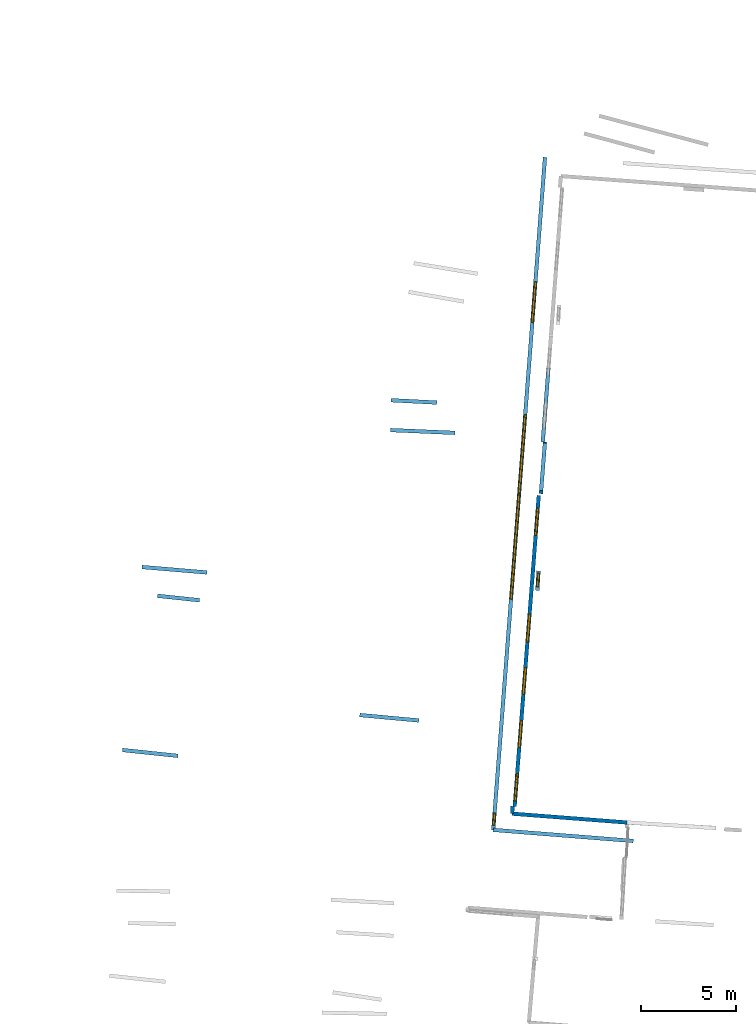
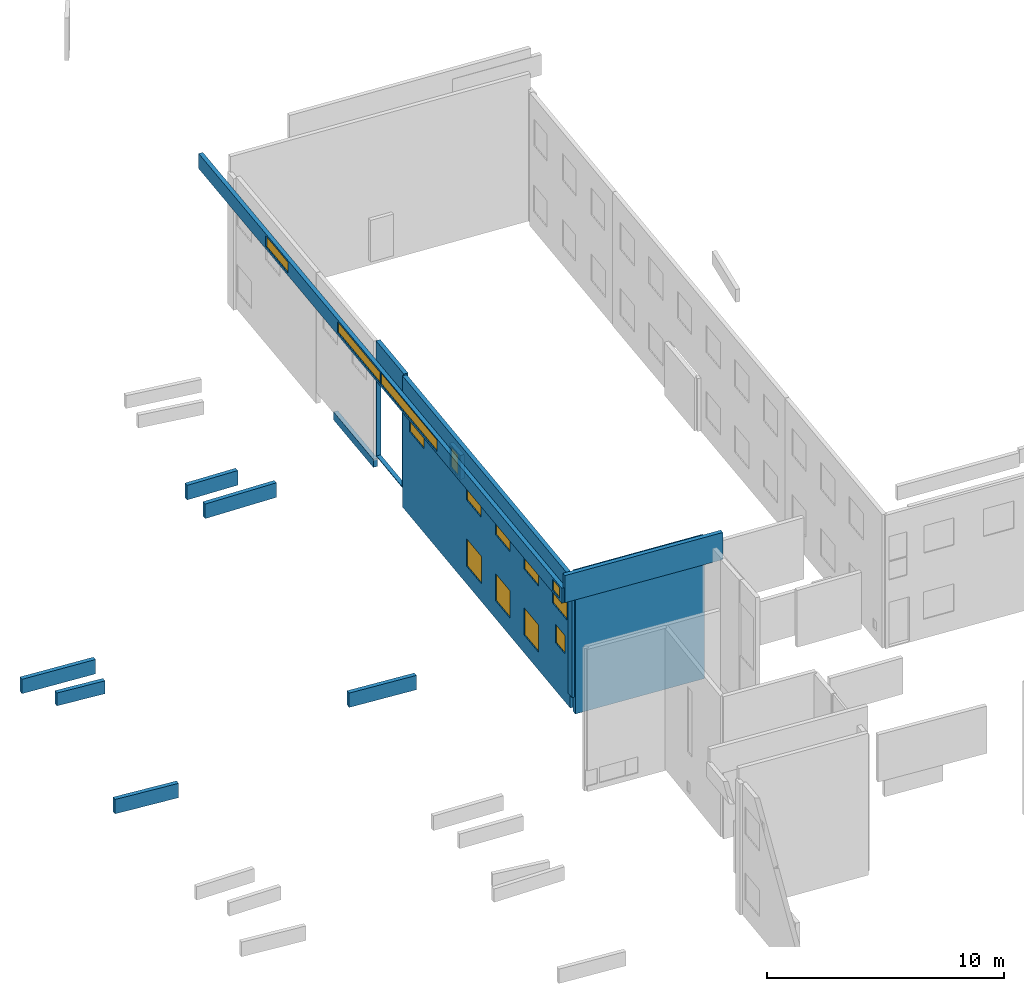
# One storey, part 9 of 27: 14 walls, 14 windows, 15 openings.
"""IFC2X3 building model written with IfcOpenShell, lengths in metres."""

from ifc_helpers import new_model, entity, si_unit, converted_unit, derived_unit, direction, frame, frame_2d, origin, origin_2d_with_axis, place, context, subcontext, project, spatial, polyline, rectangle, outline, extrude, source, transform, mapped, material, layer, layer_set, layer_usage, type_object, type_shapes, element, fill, save


model = new_model("IFC2X3")

# Units and contexts
model_context = context("Model", 3, precision=1e-05, world=origin(), true_north=direction((0.0, 1.0)))
body_context = subcontext(model_context, "Body", "Model", "MODEL_VIEW")
ifc_project = project(units=[si_unit("LENGTHUNIT", "METRE"), si_unit("AREAUNIT", "SQUARE_METRE"), si_unit("VOLUMEUNIT", "CUBIC_METRE"), converted_unit("PLANEANGLEUNIT", "DEGREE", entity("IfcRatioMeasure", 0.0174532925199433), si_unit("PLANEANGLEUNIT", "RADIAN"), dimensions=[0, 0, 0, 0, 0, 0, 0]), si_unit("MASSUNIT", "GRAM", prefix="KILO"), derived_unit("MASSDENSITYUNIT", [(si_unit("MASSUNIT", "GRAM", prefix="KILO"), 1), (si_unit("LENGTHUNIT", "METRE"), -3)]), derived_unit("MOMENTOFINERTIAUNIT", [(si_unit("LENGTHUNIT", "METRE"), 4)]), si_unit("TIMEUNIT", "SECOND"), si_unit("FREQUENCYUNIT", "HERTZ"), si_unit("THERMODYNAMICTEMPERATUREUNIT", "DEGREE_CELSIUS"), derived_unit("THERMALTRANSMITTANCEUNIT", [(si_unit("MASSUNIT", "GRAM", prefix="KILO"), 1), (si_unit("THERMODYNAMICTEMPERATUREUNIT", "KELVIN"), -1), (si_unit("TIMEUNIT", "SECOND"), -3)]), derived_unit("VOLUMETRICFLOWRATEUNIT", [(si_unit("LENGTHUNIT", "METRE"), 3), (si_unit("TIMEUNIT", "SECOND"), -1)]), si_unit("ELECTRICCURRENTUNIT", "AMPERE"), si_unit("ELECTRICVOLTAGEUNIT", "VOLT"), si_unit("POWERUNIT", "WATT"), si_unit("FORCEUNIT", "NEWTON", prefix="KILO"), si_unit("ILLUMINANCEUNIT", "LUX"), si_unit("LUMINOUSFLUXUNIT", "LUMEN"), si_unit("LUMINOUSINTENSITYUNIT", "CANDELA"), derived_unit("USERDEFINED", [(si_unit("MASSUNIT", "GRAM", prefix="KILO"), -1), (si_unit("LENGTHUNIT", "METRE"), -2), (si_unit("TIMEUNIT", "SECOND"), 3), (si_unit("LUMINOUSFLUXUNIT", "LUMEN"), 1)]), derived_unit("LINEARVELOCITYUNIT", [(si_unit("LENGTHUNIT", "METRE"), 1), (si_unit("TIMEUNIT", "SECOND"), -1)]), si_unit("PRESSUREUNIT", "PASCAL"), derived_unit("USERDEFINED", [(si_unit("LENGTHUNIT", "METRE"), -2), (si_unit("MASSUNIT", "GRAM", prefix="KILO"), 1), (si_unit("TIMEUNIT", "SECOND"), -2)]), derived_unit("LINEARFORCEUNIT", [(si_unit("MASSUNIT", "GRAM", prefix="KILO"), 1), (si_unit("LENGTHUNIT", "METRE"), 1), (si_unit("TIMEUNIT", "SECOND"), -2), (si_unit("LENGTHUNIT", "METRE"), -1)]), derived_unit("PLANARFORCEUNIT", [(si_unit("MASSUNIT", "GRAM", prefix="KILO"), 1), (si_unit("LENGTHUNIT", "METRE"), 1), (si_unit("TIMEUNIT", "SECOND"), -2), (si_unit("LENGTHUNIT", "METRE"), -2)])], contexts=[model_context])

# Site, building, storey
placement_1 = place(None, origin())
site = spatial("IfcSite", under=ifc_project, at=placement_1, CompositionType="ELEMENT")
building = spatial("IfcBuilding", under=site, at=placement_1, CompositionType="ELEMENT")
storey_placement = place(placement_1, frame((0.0, 0.0, -61.043098449707)))
storey = spatial("IfcBuildingStorey", under=building, at=storey_placement, Name="level_-61.043098", CompositionType="ELEMENT", Elevation=-61.043098449707)

# Walls
ifc_material_1 = material(Name="Default wall")
ifc_layer = layer(ifc_material_1, 0.2)
ifc_layer_set = layer_set([ifc_layer], Name="wall_thickness_0.2000")
ifc_layer_usage = layer_usage(ifc_layer_set, "AXIS2", "POSITIVE", -0.1)
wall_type = type_object("IfcWallType", Name="wall_thickness_0.2000", PredefinedType="STANDARD", material=ifc_layer_set)
placement_2 = place(placement_1, frame((0.0, 0.0, -60.9578857421875)))
wall_1_placement = place(placement_2, frame((-104.83050371707, 5.95232579703407, 0.0), z_axis=(0.0, 0.0, 1.0), x_axis=(0.994467965753538, -0.105040302217857, 0.0)))
element("IfcWallStandardCase", 1, at=wall_1_placement, inside=storey, type_object=wall_type, material=ifc_layer_usage, Name="Wall:453", ObjectType="Wall", context=body_context, shape_type="SweptSolid", body=[
    extrude(outline(polyline([(2.9369933976669, -0.1), (2.9369933976669, 0.1), (0.0, 0.1), (0.0, -0.1), (2.9369933976669, -0.1)])), origin(), (0.0, 0.0, 1.0), 0.739894866943359),
])
placement_3 = place(placement_1, frame((0.0, 0.0, -60.9578857421875)))
wall_2_placement = place(placement_3, frame((-103.806959196289, 15.56809564699, 0.0), z_axis=(0.0, 0.0, 1.0), x_axis=(0.996499432256077, -0.0835995305807164, 0.0)))
element("IfcWallStandardCase", 2, at=wall_2_placement, inside=storey, type_object=wall_type, material=ifc_layer_usage, Name="Wall:468", ObjectType="Wall", context=body_context, shape_type="SweptSolid", body=[
    extrude(outline(polyline([(3.42499908487416, -0.1), (3.42499908487416, 0.1), (0.0, 0.1), (0.0, -0.1), (3.42499908487416, -0.1)])), origin(), (0.0, 0.0, 1.0), 0.739894866943359),
])
placement_4 = place(placement_1, frame((0.0, 0.0, -60.8847198486328)))
wall_3_placement = place(placement_4, frame((-90.7094349901789, 24.3314856297393, 0.0), z_axis=(0.0, 0.0, 1.0), x_axis=(0.998708012767154, -0.0508163874619398, 0.0)))
element("IfcWallStandardCase", 3, at=wall_3_placement, inside=storey, type_object=wall_type, material=ifc_layer_usage, Name="Wall:595", ObjectType="Wall", context=body_context, shape_type="SweptSolid", body=[
    extrude(outline(polyline([(2.40143330965317, -0.1), (2.40143330965317, 0.1), (0.0, 0.1), (0.0, -0.1), (2.40143330965317, -0.1)])), origin(), (0.0, 0.0, 1.0), 0.751243591308594),
])

# Wall, openings, windows
placement_5 = place(placement_1, frame((0.0, 0.0, -60.9578857421875)))
wall_4_placement = place(placement_5, frame((-82.9530184514363, 19.3352135114914, 0.0), z_axis=(0.0, 0.0, 1.0), x_axis=(-0.0773158542007588, -0.997006649270308, 0.0)))
wall_4 = element("IfcWallStandardCase", 4, at=wall_4_placement, inside=storey, type_object=wall_type, material=ifc_layer_usage, Name="Wall:641", ObjectType="Wall", context=body_context, shape_type="SweptSolid", body=[
    extrude(outline(polyline([(16.3949994072059, -0.1), (16.3949994072059, 0.1), (0.0, 0.1), (0.0, -0.1), (16.3949994072059, -0.1)])), origin(), (0.0, 0.0, 1.0), 6.74871063232422),
])
opening_1_placement = place(wall_4_placement, frame((0.675013523373831, -0.1, 4.32080459594727)))
opening_1 = element("IfcOpeningElement", 5, at=opening_1_placement, cuts=wall_4, Name="Opening : 1420 x 1405 : 55", ObjectType="Opening", context=body_context, shape_type="SweptSolid", body=[
    extrude(rectangle(XDim=1.42, YDim=1.405, at=frame_2d((0.7025, 0.71), x_axis=(0.0, 1.0))), frame((0.0, 0.0, 0.0), z_axis=(0.0, 1.0, 0.0), x_axis=(0.0, 0.0, 1.0)), (0.0, 0.0, 1.0), 0.2),
])
opening_2_placement = place(wall_4_placement, frame((6.27501483527464, -0.1, 4.32080459594727)))
opening_2 = element("IfcOpeningElement", 6, at=opening_2_placement, cuts=wall_4, Name="Opening : 1420 x 1400 : 56", ObjectType="Opening", context=body_context, shape_type="SweptSolid", body=[
    extrude(rectangle(XDim=1.42, YDim=1.4, at=frame_2d((0.7, 0.71), x_axis=(0.0, 1.0))), frame((0.0, 0.0, 0.0), z_axis=(0.0, 1.0, 0.0), x_axis=(0.0, 0.0, 1.0)), (0.0, 0.0, 1.0), 0.2),
])
opening_3_placement = place(wall_4_placement, frame((6.26501384893207, -0.1, 0.910804748535156)))
opening_3 = element("IfcOpeningElement", 7, at=opening_3_placement, cuts=wall_4, Name="Opening : 1465 x 1415 : 57", ObjectType="Opening", context=body_context, shape_type="SweptSolid", body=[
    extrude(rectangle(XDim=1.465, YDim=1.415, at=frame_2d((0.7075, 0.7325), x_axis=(0.0, 1.0))), frame((0.0, 0.0, 0.0), z_axis=(0.0, 1.0, 0.0), x_axis=(0.0, 0.0, 1.0)), (0.0, 0.0, 1.0), 0.2),
])
opening_4_placement = place(wall_4_placement, frame((9.08499972376067, -0.1, 4.3271369934082)))
opening_4 = element("IfcOpeningElement", 8, at=opening_4_placement, cuts=wall_4, Name="Opening : 1410 x 1395 : 58", ObjectType="Opening", context=body_context, shape_type="SweptSolid", body=[
    extrude(rectangle(XDim=1.41, YDim=1.395, at=frame_2d((0.6975, 0.705), x_axis=(0.0, 1.0))), frame((0.0, 0.0, 0.0), z_axis=(0.0, 1.0, 0.0), x_axis=(0.0, 0.0, 1.0)), (0.0, 0.0, 1.0), 0.2),
])
opening_5_placement = place(wall_4_placement, frame((11.8699999654802, -0.1, 4.317138671875)))
opening_5 = element("IfcOpeningElement", 9, at=opening_5_placement, cuts=wall_4, Name="Opening : 1420 x 1400 : 59", ObjectType="Opening", context=body_context, shape_type="SweptSolid", body=[
    extrude(rectangle(XDim=1.42, YDim=1.4, at=frame_2d((0.7, 0.71), x_axis=(0.0, 1.0))), frame((0.0, 0.0, 0.0), z_axis=(0.0, 1.0, 0.0), x_axis=(0.0, 0.0, 1.0)), (0.0, 0.0, 1.0), 0.2),
])
opening_6_placement = place(wall_4_placement, frame((14.6699991952011, -0.1, 4.3271369934082)))
opening_6 = element("IfcOpeningElement", 10, at=opening_6_placement, cuts=wall_4, Name="Opening : 1420 x 1390 : 60", ObjectType="Opening", context=body_context, shape_type="SweptSolid", body=[
    extrude(rectangle(XDim=1.42, YDim=1.39, at=frame_2d((0.695, 0.71), x_axis=(0.0, 1.0))), frame((0.0, 0.0, 0.0), z_axis=(0.0, 1.0, 0.0), x_axis=(0.0, 0.0, 1.0)), (0.0, 0.0, 1.0), 0.2),
])
opening_7_placement = place(wall_4_placement, frame((14.9699989224421, -0.1, 2.46213912963867)))
opening_7 = element("IfcOpeningElement", 11, at=opening_7_placement, cuts=wall_4, Name="Opening : 895 x 945 : 61", ObjectType="Opening", context=body_context, shape_type="SweptSolid", body=[
    extrude(rectangle(XDim=0.895, YDim=0.945, at=frame_2d((0.4725, 0.4475), x_axis=(0.0, 1.0))), frame((0.0, 0.0, 0.0), z_axis=(0.0, 1.0, 0.0), x_axis=(0.0, 0.0, 1.0)), (0.0, 0.0, 1.0), 0.2),
])
opening_8_placement = place(wall_4_placement, frame((9.0799997059992, -0.1, 0.917137145996094)))
opening_8 = element("IfcOpeningElement", 12, at=opening_8_placement, cuts=wall_4, Name="Opening : 1410 x 1400 : 62", ObjectType="Opening", context=body_context, shape_type="SweptSolid", body=[
    extrude(rectangle(XDim=1.41, YDim=1.4, at=frame_2d((0.7, 0.705), x_axis=(0.0, 1.0))), frame((0.0, 0.0, 0.0), z_axis=(0.0, 1.0, 0.0), x_axis=(0.0, 0.0, 1.0)), (0.0, 0.0, 1.0), 0.2),
])
opening_9_placement = place(wall_4_placement, frame((11.8749999832417, -0.1, 0.917137145996094)))
opening_9 = element("IfcOpeningElement", 13, at=opening_9_placement, cuts=wall_4, Name="Opening : 1415 x 1400 : 63", ObjectType="Opening", context=body_context, shape_type="SweptSolid", body=[
    extrude(rectangle(XDim=1.415, YDim=1.4, at=frame_2d((0.7, 0.7075), x_axis=(0.0, 1.0))), frame((0.0, 0.0, 0.0), z_axis=(0.0, 1.0, 0.0), x_axis=(0.0, 0.0, 1.0)), (0.0, 0.0, 1.0), 0.2),
])
ifc_material_2 = material(Name="Window Default")
window_style_1 = type_object("IfcWindowStyle", Name="Window : 1420 x 1390mm", ConstructionType="NOTDEFINED", OperationType="NOTDEFINED", ParameterTakesPrecedence=False, Sizeable=False, material=ifc_material_2)
shared_shape_1 = source(origin(), body_context, "Body", "SweptSolid", [
    extrude(rectangle(XDim=0.1, YDim=1.42, at=origin_2d_with_axis()), frame((0.71, 0.1, 0.0), z_axis=(0.0, 0.0, 1.0), x_axis=(0.0, 1.0, 0.0)), (0.0, 0.0, 1.0), 1.39),
])
type_shapes(window_style_1, [shared_shape_1])
window_1_placement = place(opening_6_placement, origin())
window_1 = element("IfcWindow", 14, at=window_1_placement, inside=storey, type_object=window_style_1, Name="Window : 1420 x 1390mm : 52", ObjectType="Window : 1420 x 1390mm", OverallHeight=1.39, OverallWidth=1.42, context=body_context, shape_type="MappedRepresentation", body=[
    mapped(shared_shape_1, transform((0.0, 0.0, 0.0), scale=1.0)),
])
fill(opening_6, window_1)
window_style_2 = type_object("IfcWindowStyle", Name="Window : 1410 x 1395mm", ConstructionType="NOTDEFINED", OperationType="NOTDEFINED", ParameterTakesPrecedence=False, Sizeable=False, material=ifc_material_2)
shared_shape_2 = source(origin(), body_context, "Body", "SweptSolid", [
    extrude(rectangle(XDim=0.1, YDim=1.41, at=origin_2d_with_axis()), frame((0.705, 0.1, 0.0), z_axis=(0.0, 0.0, 1.0), x_axis=(0.0, 1.0, 0.0)), (0.0, 0.0, 1.0), 1.395),
])
type_shapes(window_style_2, [shared_shape_2])
window_2_placement = place(opening_4_placement, origin())
window_2 = element("IfcWindow", 15, at=window_2_placement, inside=storey, type_object=window_style_2, Name="Window : 1410 x 1395mm : 50", ObjectType="Window : 1410 x 1395mm", OverallHeight=1.395, OverallWidth=1.41, context=body_context, shape_type="MappedRepresentation", body=[
    mapped(shared_shape_2, transform((0.0, 0.0, 0.0), scale=1.0)),
])
fill(opening_4, window_2)
window_style_3 = type_object("IfcWindowStyle", Name="Window : 1420 x 1400mm", ConstructionType="NOTDEFINED", OperationType="NOTDEFINED", ParameterTakesPrecedence=False, Sizeable=False, material=ifc_material_2)
shared_shape_3 = source(origin(), body_context, "Body", "SweptSolid", [
    extrude(rectangle(XDim=0.1, YDim=1.42, at=origin_2d_with_axis()), frame((0.71, 0.1, 0.0), z_axis=(0.0, 0.0, 1.0), x_axis=(0.0, 1.0, 0.0)), (0.0, 0.0, 1.0), 1.4),
])
type_shapes(window_style_3, [shared_shape_3])
window_3_placement = place(opening_2_placement, origin())
window_3 = element("IfcWindow", 16, at=window_3_placement, inside=storey, type_object=window_style_3, Name="Window : 1420 x 1400mm : 48", ObjectType="Window : 1420 x 1400mm", OverallHeight=1.4, OverallWidth=1.42, context=body_context, shape_type="MappedRepresentation", body=[
    mapped(shared_shape_3, transform((0.0, 0.0, 0.0), scale=1.0)),
])
fill(opening_2, window_3)
window_4_placement = place(opening_5_placement, origin())
window_4 = element("IfcWindow", 17, at=window_4_placement, inside=storey, type_object=window_style_3, Name="Window : 1420 x 1400mm : 51", ObjectType="Window : 1420 x 1400mm", OverallHeight=1.4, OverallWidth=1.42, context=body_context, shape_type="MappedRepresentation", body=[
    mapped(shared_shape_3, transform((0.0, 0.0, 0.0), scale=1.0)),
])
fill(opening_5, window_4)
window_style_4 = type_object("IfcWindowStyle", Name="Window : 1420 x 1405mm", ConstructionType="NOTDEFINED", OperationType="NOTDEFINED", ParameterTakesPrecedence=False, Sizeable=False, material=ifc_material_2)
shared_shape_4 = source(origin(), body_context, "Body", "SweptSolid", [
    extrude(rectangle(XDim=0.1, YDim=1.42, at=origin_2d_with_axis()), frame((0.71, 0.1, 0.0), z_axis=(0.0, 0.0, 1.0), x_axis=(0.0, 1.0, 0.0)), (0.0, 0.0, 1.0), 1.405),
])
type_shapes(window_style_4, [shared_shape_4])
window_5_placement = place(opening_1_placement, origin())
window_5 = element("IfcWindow", 18, at=window_5_placement, inside=storey, type_object=window_style_4, Name="Window : 1420 x 1405mm : 47", ObjectType="Window : 1420 x 1405mm", OverallHeight=1.405, OverallWidth=1.42, context=body_context, shape_type="MappedRepresentation", body=[
    mapped(shared_shape_4, transform((0.0, 0.0, 0.0), scale=1.0)),
])
fill(opening_1, window_5)
window_style_5 = type_object("IfcWindowStyle", Name="Window : 1465 x 1415mm", ConstructionType="NOTDEFINED", OperationType="NOTDEFINED", ParameterTakesPrecedence=False, Sizeable=False, material=ifc_material_2)
shared_shape_5 = source(origin(), body_context, "Body", "SweptSolid", [
    extrude(rectangle(XDim=0.1, YDim=1.465, at=origin_2d_with_axis()), frame((0.7325, 0.1, 0.0), z_axis=(0.0, 0.0, 1.0), x_axis=(0.0, 1.0, 0.0)), (0.0, 0.0, 1.0), 1.415),
])
type_shapes(window_style_5, [shared_shape_5])
window_6_placement = place(opening_3_placement, origin())
window_6 = element("IfcWindow", 19, at=window_6_placement, inside=storey, type_object=window_style_5, Name="Window : 1465 x 1415mm : 49", ObjectType="Window : 1465 x 1415mm", OverallHeight=1.415, OverallWidth=1.465, context=body_context, shape_type="MappedRepresentation", body=[
    mapped(shared_shape_5, transform((0.0, 0.0, 0.0), scale=1.0)),
])
fill(opening_3, window_6)
window_style_6 = type_object("IfcWindowStyle", Name="Window : 895 x 945mm", ConstructionType="NOTDEFINED", OperationType="NOTDEFINED", ParameterTakesPrecedence=False, Sizeable=False, material=ifc_material_2)
shared_shape_6 = source(origin(), body_context, "Body", "SweptSolid", [
    extrude(rectangle(XDim=0.1, YDim=0.895, at=origin_2d_with_axis()), frame((0.4475, 0.1, 0.0), z_axis=(0.0, 0.0, 1.0), x_axis=(0.0, 1.0, 0.0)), (0.0, 0.0, 1.0), 0.945),
])
type_shapes(window_style_6, [shared_shape_6])
window_7_placement = place(opening_7_placement, origin())
window_7 = element("IfcWindow", 20, at=window_7_placement, inside=storey, type_object=window_style_6, Name="Window : 895 x 945mm : 53", ObjectType="Window : 895 x 945mm", OverallHeight=0.945, OverallWidth=0.895, context=body_context, shape_type="MappedRepresentation", body=[
    mapped(shared_shape_6, transform((0.0, 0.0, 0.0), scale=1.0)),
])
fill(opening_7, window_7)
window_style_7 = type_object("IfcWindowStyle", Name="Window : 1410 x 1400mm", ConstructionType="NOTDEFINED", OperationType="NOTDEFINED", ParameterTakesPrecedence=False, Sizeable=False, material=ifc_material_2)
shared_shape_7 = source(origin(), body_context, "Body", "SweptSolid", [
    extrude(rectangle(XDim=0.1, YDim=1.41, at=origin_2d_with_axis()), frame((0.705, 0.1, 0.0), z_axis=(0.0, 0.0, 1.0), x_axis=(0.0, 1.0, 0.0)), (0.0, 0.0, 1.0), 1.4),
])
type_shapes(window_style_7, [shared_shape_7])
window_8_placement = place(opening_8_placement, origin())
window_8 = element("IfcWindow", 21, at=window_8_placement, inside=storey, type_object=window_style_7, Name="Window : 1410 x 1400mm : 54", ObjectType="Window : 1410 x 1400mm", OverallHeight=1.4, OverallWidth=1.41, context=body_context, shape_type="MappedRepresentation", body=[
    mapped(shared_shape_7, transform((0.0, 0.0, 0.0), scale=1.0)),
])
fill(opening_8, window_8)
window_style_8 = type_object("IfcWindowStyle", Name="Window : 1415 x 1400mm", ConstructionType="NOTDEFINED", OperationType="NOTDEFINED", ParameterTakesPrecedence=False, Sizeable=False, material=ifc_material_2)
shared_shape_8 = source(origin(), body_context, "Body", "SweptSolid", [
    extrude(rectangle(XDim=0.1, YDim=1.415, at=origin_2d_with_axis()), frame((0.7075, 0.1, 0.0), z_axis=(0.0, 0.0, 1.0), x_axis=(0.0, 1.0, 0.0)), (0.0, 0.0, 1.0), 1.4),
])
type_shapes(window_style_8, [shared_shape_8])
window_9_placement = place(opening_9_placement, origin())
window_9 = element("IfcWindow", 22, at=window_9_placement, inside=storey, type_object=window_style_8, Name="Window : 1415 x 1400mm : 55", ObjectType="Window : 1415 x 1400mm", OverallHeight=1.4, OverallWidth=1.415, context=body_context, shape_type="MappedRepresentation", body=[
    mapped(shared_shape_8, transform((0.0, 0.0, 0.0), scale=1.0)),
])
fill(opening_9, window_9)

# Wall, opening, window
placement_6 = place(placement_1, frame((0.0, 0.0, -56.5068283081055)))
wall_5_placement = place(placement_6, frame((-82.9640993806233, 15.3668243942902, 0.0), z_axis=(0.0, 0.0, 1.0), x_axis=(-0.0612829185740148, -0.998120435564291, 0.0)))
wall_5 = element("IfcWallStandardCase", 23, at=wall_5_placement, inside=storey, type_object=wall_type, material=ifc_layer_usage, Name="Wall:779", ObjectType="Wall", context=body_context, shape_type="SweptSolid", body=[
    extrude(outline(polyline([(1.02583578589804, -0.1), (1.02583578589804, 0.1), (0.0, 0.1), (0.0, -0.1), (1.02583578589804, -0.1)])), origin(), (0.0, 0.0, 1.0), 1.24327087402344),
])
opening_10_placement = place(wall_5_placement, frame((0.130000438263326, -0.1, 0.0762100219726562)))
opening_10 = element("IfcOpeningElement", 24, at=opening_10_placement, cuts=wall_5, Name="Opening : 700 x 1085 : 78", ObjectType="Opening", context=body_context, shape_type="SweptSolid", body=[
    extrude(rectangle(XDim=0.7, YDim=1.085, at=frame_2d((0.5425, 0.35), x_axis=(0.0, 1.0))), frame((0.0, 0.0, 0.0), z_axis=(0.0, 1.0, 0.0), x_axis=(0.0, 0.0, 1.0)), (0.0, 0.0, 1.0), 0.2),
])
window_style_9 = type_object("IfcWindowStyle", Name="Window : 700 x 1085mm", ConstructionType="NOTDEFINED", OperationType="NOTDEFINED", ParameterTakesPrecedence=False, Sizeable=False, material=ifc_material_2)
shared_shape_9 = source(origin(), body_context, "Body", "SweptSolid", [
    extrude(rectangle(XDim=0.1, YDim=0.7, at=origin_2d_with_axis()), frame((0.35, 0.1, 0.0), z_axis=(0.0, 0.0, 1.0), x_axis=(0.0, 1.0, 0.0)), (0.0, 0.0, 1.0), 1.085),
])
type_shapes(window_style_9, [shared_shape_9])
window_10_placement = place(opening_10_placement, origin())
window_10 = element("IfcWindow", 25, at=window_10_placement, inside=storey, type_object=window_style_9, Name="Window : 700 x 1085mm : 70", ObjectType="Window : 700 x 1085mm", OverallHeight=1.085, OverallWidth=0.7, context=body_context, shape_type="MappedRepresentation", body=[
    mapped(shared_shape_9, transform((0.0, 0.0, 0.0), scale=1.0)),
])
fill(opening_10, window_10)

# Walls
placement_7 = place(placement_1, frame((0.0, 0.0, -60.9578857421875)))
wall_6_placement = place(placement_7, frame((-92.3612878438804, 7.79108499017711, 0.0), z_axis=(0.0, 0.0, 1.0), x_axis=(0.995752957791469, -0.0920654498144671, 0.0)))
element("IfcWallStandardCase", 26, at=wall_6_placement, inside=storey, type_object=wall_type, material=ifc_layer_usage, Name="Wall:1055", ObjectType="Wall", context=body_context, shape_type="SweptSolid", body=[
    extrude(outline(polyline([(3.12000126534584, -0.1), (3.12000126534584, 0.1), (0.0, 0.1), (0.0, -0.1), (3.12000126534584, -0.1)])), origin(), (0.0, 0.0, 1.0), 0.739894866943359),
])
placement_8 = place(placement_1, frame((0.0, 0.0, -54.3638687133789)))
wall_7_placement = place(placement_8, frame((-85.343469631482, 1.75467058064514, 0.0), z_axis=(0.0, 0.0, 1.0), x_axis=(0.996894037972469, -0.0787545367261251, 0.0)))
element("IfcWallStandardCase", 27, at=wall_7_placement, inside=storey, type_object=wall_type, material=ifc_layer_usage, Name="Wall:1064", ObjectType="Wall", context=body_context, shape_type="SweptSolid", body=[
    extrude(outline(polyline([(7.37938830053145, -0.1), (7.37938830053145, 0.1), (0.0, 0.1), (0.0, -0.1), (7.37938830053145, -0.1)])), origin(), (0.0, 0.0, 1.0), 1.39701843261719),
])

# Wall, openings, windows
placement_9 = place(placement_1, frame((0.0, 0.0, -54.4207000732422)))
wall_8_placement = place(placement_9, frame((-85.3434570155329, 1.75466694877155, 0.0), z_axis=(0.0, 0.0, 1.0), x_axis=(0.0766910758956936, 0.99705490263975, 0.0)))
wall_8 = element("IfcWallStandardCase", 28, at=wall_8_placement, inside=storey, type_object=wall_type, material=ifc_layer_usage, Name="Wall:1129", ObjectType="Wall", context=body_context, shape_type="SweptSolid", body=[
    extrude(outline(polyline([(35.4487795320728, -0.1), (35.4487795320728, 0.1), (0.0, 0.1), (0.0, -0.1), (35.4487795320728, -0.1)])), origin(), (0.0, 0.0, 1.0), 0.772296905517578),
])
opening_11_placement = place(wall_8_placement, frame((12.1673553235287, -0.1, 0.117298126220703)))
opening_11 = element("IfcOpeningElement", 29, at=opening_11_placement, cuts=wall_8, Name="Opening : 5515 x 595 : 159", ObjectType="Opening", context=body_context, shape_type="SweptSolid", body=[
    extrude(rectangle(XDim=5.515, YDim=0.595, at=frame_2d((0.2975, 2.7575), x_axis=(0.0, 1.0))), frame((0.0, 0.0, 0.0), z_axis=(0.0, 1.0, 0.0), x_axis=(0.0, 0.0, 1.0)), (0.0, 0.0, 1.0), 0.2),
])
opening_12_placement = place(wall_8_placement, frame((17.7573543547339, -0.1, 0.122299194335938)))
opening_12 = element("IfcOpeningElement", 30, at=opening_12_placement, cuts=wall_8, Name="Opening : 4125 x 555 : 160", ObjectType="Opening", context=body_context, shape_type="SweptSolid", body=[
    extrude(rectangle(XDim=4.125, YDim=0.555, at=frame_2d((0.2775, 2.0625), x_axis=(0.0, 1.0))), frame((0.0, 0.0, 0.0), z_axis=(0.0, 1.0, 0.0), x_axis=(0.0, 0.0, 1.0)), (0.0, 0.0, 1.0), 0.2),
])
opening_13_placement = place(wall_8_placement, frame((26.7423556066121, -0.1, 0.122299194335938)))
opening_13 = element("IfcOpeningElement", 31, at=opening_13_placement, cuts=wall_8, Name="Opening : 2155 x 555 : 161", ObjectType="Opening", context=body_context, shape_type="SweptSolid", body=[
    extrude(rectangle(XDim=2.155, YDim=0.555, at=frame_2d((0.2775, 1.0775), x_axis=(0.0, 1.0))), frame((0.0, 0.0, 0.0), z_axis=(0.0, 1.0, 0.0), x_axis=(0.0, 0.0, 1.0)), (0.0, 0.0, 1.0), 0.2),
])
opening_14_placement = place(wall_8_placement, frame((0.242355650499457, -0.1, 0.107295989990234)))
opening_14 = element("IfcOpeningElement", 32, at=opening_14_placement, cuts=wall_8, Name="Opening : 645 x 555 : 162", ObjectType="Opening", context=body_context, shape_type="SweptSolid", body=[
    extrude(rectangle(XDim=0.645, YDim=0.555, at=frame_2d((0.2775, 0.3225), x_axis=(0.0, 1.0))), frame((0.0, 0.0, 0.0), z_axis=(0.0, 1.0, 0.0), x_axis=(0.0, 0.0, 1.0)), (0.0, 0.0, 1.0), 0.2),
])
window_style_10 = type_object("IfcWindowStyle", Name="Window : 5515 x 595mm", ConstructionType="NOTDEFINED", OperationType="NOTDEFINED", ParameterTakesPrecedence=False, Sizeable=False, material=ifc_material_2)
shared_shape_10 = source(origin(), body_context, "Body", "SweptSolid", [
    extrude(rectangle(XDim=0.1, YDim=5.515, at=origin_2d_with_axis()), frame((2.7575, 0.1, 0.0), z_axis=(0.0, 0.0, 1.0), x_axis=(0.0, 1.0, 0.0)), (0.0, 0.0, 1.0), 0.595),
])
type_shapes(window_style_10, [shared_shape_10])
window_11_placement = place(opening_11_placement, origin())
window_11 = element("IfcWindow", 33, at=window_11_placement, inside=storey, type_object=window_style_10, Name="Window : 5515 x 595mm : 145", ObjectType="Window : 5515 x 595mm", OverallHeight=0.595, OverallWidth=5.515, context=body_context, shape_type="MappedRepresentation", body=[
    mapped(shared_shape_10, transform((0.0, 0.0, 0.0), scale=1.0)),
])
fill(opening_11, window_11)
window_style_11 = type_object("IfcWindowStyle", Name="Window : 4125 x 555mm", ConstructionType="NOTDEFINED", OperationType="NOTDEFINED", ParameterTakesPrecedence=False, Sizeable=False, material=ifc_material_2)
shared_shape_11 = source(origin(), body_context, "Body", "SweptSolid", [
    extrude(rectangle(XDim=0.1, YDim=4.125, at=origin_2d_with_axis()), frame((2.0625, 0.1, 0.0), z_axis=(0.0, 0.0, 1.0), x_axis=(0.0, 1.0, 0.0)), (0.0, 0.0, 1.0), 0.555),
])
type_shapes(window_style_11, [shared_shape_11])
window_12_placement = place(opening_12_placement, origin())
window_12 = element("IfcWindow", 34, at=window_12_placement, inside=storey, type_object=window_style_11, Name="Window : 4125 x 555mm : 146", ObjectType="Window : 4125 x 555mm", OverallHeight=0.555, OverallWidth=4.125, context=body_context, shape_type="MappedRepresentation", body=[
    mapped(shared_shape_11, transform((0.0, 0.0, 0.0), scale=1.0)),
])
fill(opening_12, window_12)
window_style_12 = type_object("IfcWindowStyle", Name="Window : 2155 x 555mm", ConstructionType="NOTDEFINED", OperationType="NOTDEFINED", ParameterTakesPrecedence=False, Sizeable=False, material=ifc_material_2)
shared_shape_12 = source(origin(), body_context, "Body", "SweptSolid", [
    extrude(rectangle(XDim=0.1, YDim=2.155, at=origin_2d_with_axis()), frame((1.0775, 0.1, 0.0), z_axis=(0.0, 0.0, 1.0), x_axis=(0.0, 1.0, 0.0)), (0.0, 0.0, 1.0), 0.555),
])
type_shapes(window_style_12, [shared_shape_12])
window_13_placement = place(opening_13_placement, origin())
window_13 = element("IfcWindow", 35, at=window_13_placement, inside=storey, type_object=window_style_12, Name="Window : 2155 x 555mm : 147", ObjectType="Window : 2155 x 555mm", OverallHeight=0.555, OverallWidth=2.155, context=body_context, shape_type="MappedRepresentation", body=[
    mapped(shared_shape_12, transform((0.0, 0.0, 0.0), scale=1.0)),
])
fill(opening_13, window_13)
window_style_13 = type_object("IfcWindowStyle", Name="Window : 645 x 555mm", ConstructionType="NOTDEFINED", OperationType="NOTDEFINED", ParameterTakesPrecedence=False, Sizeable=False, material=ifc_material_2)
shared_shape_13 = source(origin(), body_context, "Body", "SweptSolid", [
    extrude(rectangle(XDim=0.1, YDim=0.645, at=origin_2d_with_axis()), frame((0.3225, 0.1, 0.0), z_axis=(0.0, 0.0, 1.0), x_axis=(0.0, 1.0, 0.0)), (0.0, 0.0, 1.0), 0.555),
])
type_shapes(window_style_13, [shared_shape_13])
window_14_placement = place(opening_14_placement, origin())
window_14 = element("IfcWindow", 36, at=window_14_placement, inside=storey, type_object=window_style_13, Name="Window : 645 x 555mm : 148", ObjectType="Window : 645 x 555mm", OverallHeight=0.555, OverallWidth=0.645, context=body_context, shape_type="MappedRepresentation", body=[
    mapped(shared_shape_13, transform((0.0, 0.0, 0.0), scale=1.0)),
])
fill(opening_14, window_14)

# Wall, opening
placement_10 = place(placement_1, frame((0.0, 0.0, -60.1485977172852)))
wall_9_placement = place(placement_10, frame((-82.6279931067933, 22.1304512602279, 0.0), z_axis=(0.0, 0.0, 1.0), x_axis=(-0.0785631071633955, -0.996909142396052, 0.0)))
wall_9 = element("IfcWallStandardCase", 37, at=wall_9_placement, inside=storey, type_object=wall_type, material=ifc_layer_usage, Name="Wall:1163", ObjectType="Wall", context=body_context, shape_type="SweptSolid", body=[
    extrude(outline(polyline([(2.72000076297066, -0.1), (2.72000076297066, 0.1), (0.0, 0.1), (0.0, -0.1), (2.72000076297066, -0.1)])), origin(), (0.0, 0.0, 1.0), 5.93942260742188),
])
opening_15_placement = place(wall_9_placement, frame((0.0550009307822713, -0.1, 0.0393791198730469)))
element("IfcOpeningElement", 38, at=opening_15_placement, cuts=wall_9, Name="Opening : 2485 x 4845 : 163", ObjectType="Opening", context=body_context, shape_type="SweptSolid", body=[
    extrude(rectangle(XDim=2.485, YDim=4.845, at=frame_2d((2.4225, 1.2425), x_axis=(0.0, 1.0))), frame((0.0, 0.0, 0.0), z_axis=(0.0, 1.0, 0.0), x_axis=(0.0, 0.0, 1.0)), (0.0, 0.0, 1.0), 0.2),
])

# Walls
placement_11 = place(placement_1, frame((0.0, 0.0, -60.7112045288086)))
wall_10_placement = place(placement_11, frame((-82.7426049190294, 22.1577550732944, 0.0), z_axis=(0.0, 0.0, 1.0), x_axis=(0.0769979062466145, 0.997031254491873, 0.0)))
element("IfcWallStandardCase", 39, at=wall_10_placement, inside=storey, type_object=wall_type, material=ifc_layer_usage, Name="Wall:1210", ObjectType="Wall", context=body_context, shape_type="SweptSolid", body=[
    extrude(outline(polyline([(3.87999941320253, -0.1), (3.87999941320253, 0.1), (0.0, 0.1), (0.0, -0.1), (3.87999941320253, -0.1)])), origin(), (0.0, 0.0, 1.0), 0.415069580078125),
])
placement_12 = place(placement_1, frame((0.0, 0.0, -60.1485977172852)))
wall_11_placement = place(placement_12, frame((-84.3470494023004, 2.60652693863771, 0.0), z_axis=(0.0, 0.0, 1.0), x_axis=(0.0363345662399236, 0.999339681637909, 0.0)))
element("IfcWallStandardCase", 40, at=wall_11_placement, inside=storey, type_object=wall_type, material=ifc_layer_usage, Name="Wall:1343", ObjectType="Wall", context=body_context, shape_type="SweptSolid", body=[
    extrude(outline(polyline([(0.390765727844454, -0.1), (0.390765727844454, 0.1), (0.0, 0.1), (0.0, -0.1), (0.390765727844454, -0.1)])), origin(), (0.0, 0.0, 1.0), 5.86769104003906),
])
placement_13 = place(placement_1, frame((0.0, 0.0, -60.8847198486328)))
wall_12_placement = place(placement_13, frame((-90.7359779229598, 22.7630543839466, 0.0), z_axis=(0.0, 0.0, 1.0), x_axis=(0.999074100042734, -0.0430225827188533, 0.0)))
element("IfcWallStandardCase", 41, at=wall_12_placement, inside=storey, type_object=wall_type, material=ifc_layer_usage, Name="Wall:1416", ObjectType="Wall", context=body_context, shape_type="SweptSolid", body=[
    extrude(outline(polyline([(3.39001778460705, -0.1), (3.39001778460705, 0.1), (0.0, 0.1), (0.0, -0.1), (3.39001778460705, -0.1)])), origin(), (0.0, 0.0, 1.0), 0.751243591308594),
])
placement_14 = place(placement_1, frame((0.0, 0.0, -60.9578857421875)))
wall_13_placement = place(placement_14, frame((-102.98168353068, 14.0547298906208, 0.0), z_axis=(0.0, 0.0, 1.0), x_axis=(0.994419573798232, -0.105497446637077, 0.0)))
element("IfcWallStandardCase", 42, at=wall_13_placement, inside=storey, type_object=wall_type, material=ifc_layer_usage, Name="Wall:1777", ObjectType="Wall", context=body_context, shape_type="SweptSolid", body=[
    extrude(outline(polyline([(2.21999962807681, -0.1), (2.21999962807681, 0.1), (0.0, 0.1), (0.0, -0.1), (2.21999962807681, -0.1)])), origin(), (0.0, 0.0, 1.0), 0.661750793457031),
])
placement_15 = place(placement_1, frame((0.0, 0.0, -60.9578857421875)))
wall_14_placement = place(placement_15, frame((-78.3152727175815, 2.14240556430837, 0.0), z_axis=(0.0, 0.0, 1.0), x_axis=(-0.997052736807476, 0.076719228520124, 0.0)))
element("IfcWallStandardCase", 43, at=wall_14_placement, inside=storey, type_object=wall_type, material=ifc_layer_usage, Name="Wall:1844", ObjectType="Wall", context=body_context, shape_type="SweptSolid", body=[
    extrude(outline(polyline([(6.04962151382813, -0.1), (6.04962151382813, 0.1), (0.0, 0.1), (0.0, -0.1), (6.04962151382813, -0.1)])), origin(), (0.0, 0.0, 1.0), 7.30948257446289),
])

save(model, "model.ifc")
